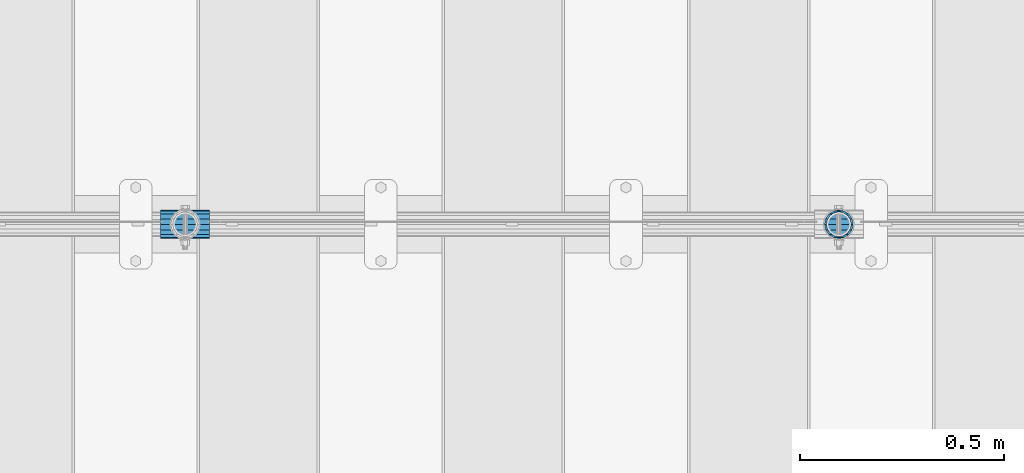
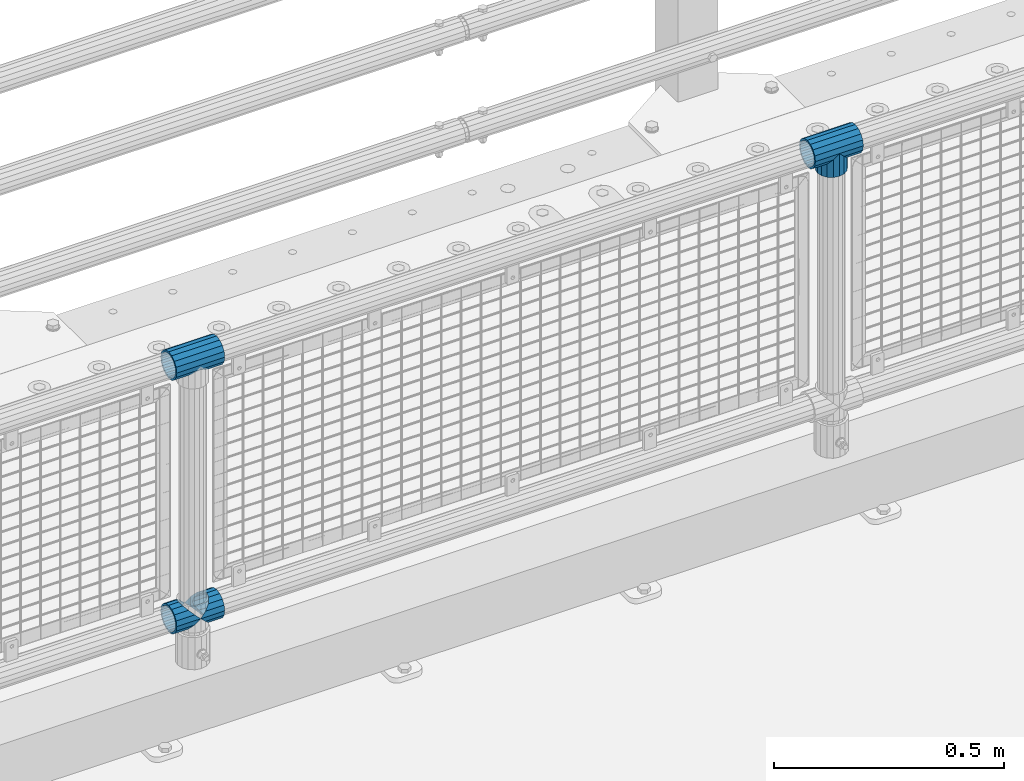
# One storey, part 150 of 257: 5 beams.
"""IFC2X3 building model written with IfcOpenShell, lengths in millimetres."""

from ifc_helpers import new_model, si_unit, frame, origin_with_axes, place, context, subcontext, project, spatial, faceted_brep, material, type_object, element, save


model = new_model("IFC2X3")

# Units and contexts
model_context = context("Model", 3, precision=1e-05, world=origin_with_axes())
body_context = subcontext(model_context, "Body", "Model", "MODEL_VIEW")
ifc_project = project(units=[si_unit("LENGTHUNIT", "METRE", prefix="MILLI"), si_unit("AREAUNIT", "SQUARE_METRE"), si_unit("VOLUMEUNIT", "CUBIC_METRE"), si_unit("MASSUNIT", "GRAM", prefix="KILO"), si_unit("TIMEUNIT", "SECOND"), si_unit("PLANEANGLEUNIT", "RADIAN"), si_unit("SOLIDANGLEUNIT", "STERADIAN"), si_unit("THERMODYNAMICTEMPERATUREUNIT", "DEGREE_CELSIUS"), si_unit("LUMINOUSINTENSITYUNIT", "LUMEN")], contexts=[model_context])

# Site, building, storey
site_placement = place(None, origin_with_axes())
site = spatial("IfcSite", under=ifc_project, at=site_placement, CompositionType="ELEMENT")
building_placement = place(site_placement, origin_with_axes())
building = spatial("IfcBuilding", under=site, at=building_placement, Name="Standard", CompositionType="ELEMENT")
storey_placement = place(building_placement, origin_with_axes())
storey = spatial("IfcBuildingStorey", under=building, at=storey_placement, Name="Undefined", CompositionType="ELEMENT", Elevation=0.0)

# Beams
ifc_material = material(Name="Misc_Undefined")
beam_type = type_object("IfcBeamType", PredefinedType="NOTDEFINED")
beam_1_placement = place(storey_placement, frame((47871.0, 10664.5, 969.849999999999), z_axis=(0.0, 1.0, 0.0), x_axis=(0.0, 0.0, -1.0)))
element("IfcBeam", 1, at=beam_1_placement, inside=storey, type_object=beam_type, material=ifc_material, context=body_context, shape_type="Brep", body=[
    faceted_brep([(0.0, 0.0, 35.1499999999996), (13.4513226476338, 13.4513226476329, 32.4743655677721), (13.4513226476338, -13.4513226476329, 32.4743655677721), (32.4743655677739, -32.4743655677717, -13.4513226476338), (32.4743655677739, -26.8123795176755, -13.4513226476338), (27.1226768591005, -21.4606908090117, -21.4606908090118), (24.8548033587067, -16.3810424080045, -24.8548033587067), (24.8548033587067, -24.8548033587072, -24.8548033587067), (13.4513226476338, -13.4513226476329, -32.4743655677721), (13.4513226476338, 13.4513226476329, -32.4743655677721), (0.0, 0.0, -35.1499999999996), (20.0882031229849, -11.6144421722805, -28.0397438117179), (16.6306603983685, 0.0, -30.3500000000004), (20.0882031229849, 11.6144421722805, -28.0397438117179), (24.8548033587067, 16.3810424080013, -24.8548033587067), (24.8548033587067, 24.8548033587072, -24.8548033587067), (32.4743655677739, 26.8123795176754, -13.4513226476338), (32.4743655677739, 32.4743655677717, -13.4513226476338), (27.1226768591005, 21.4606908090117, -21.4606908090118), (35.1500000000015, 30.35, 0.0), (35.1500000000015, 35.15, 0.0), (32.8397438117172, 28.0397438117175, -11.6144421722802), (32.8397438117172, 28.0397438117175, 11.6144421722802), (32.4743655677739, 26.8123795176755, 13.4513226476338), (32.4743655677739, 32.4743655677717, 13.4513226476338), (27.122676859115, 21.4606908090117, 21.4606908090118), (24.8548033587067, 16.3810424080013, 24.8548033587067), (24.8548033587067, 24.8548033587072, 24.8548033587067), (20.0882031229849, 11.6144421722805, 28.0397438117179), (16.6306603983758, 0.0, 30.3500000000004), (20.0882031229849, -11.6144421722805, 28.0397438117179), (24.8548033587067, -16.3810424080013, 24.8548033587067), (24.8548033587067, -24.8548033587072, 24.8548033587067), (27.122676859115, -21.4606908090117, 21.4606908090118), (32.4743655677739, -26.8123795176754, 13.4513226476338), (32.4743655677739, -32.4743655677717, 13.4513226476338), (32.8397438117172, -28.0397438117175, 11.6144421722802), (35.1500000000015, -30.35, 0.0), (35.1500000000015, -35.1499999999996, 0.0), (32.8397438117172, -28.0397438117175, -11.6144421722802), (60.1500000000015, -24.8548033587072, -24.8548033587067), (60.1500000000015, -32.4743655677717, -13.4513226476338), (60.1500000000015, -13.4513226476329, -32.4743655677721), (60.1500000000015, 0.0, -35.1499999999996), (60.1500000000015, 13.4513226476329, -32.4743655677721), (60.1500000000015, 24.8548033587072, -24.8548033587067), (60.1500000000015, 32.4743655677717, -13.4513226476338), (60.1500000000015, 35.15, 0.0), (60.1500000000015, 32.4743655677717, 13.4513226476338), (60.1500000000015, 24.8548033587072, 24.8548033587067), (60.1500000000015, 13.4513226476329, 32.4743655677721), (60.1500000000015, 0.0, 35.1499999999996), (60.1500000000015, -13.4513226476329, 32.4743655677721), (60.1500000000015, -24.8548033587072, 24.8548033587067), (60.1500000000015, -32.4743655677717, 13.4513226476338), (60.1500000000015, -35.15, 0.0), (60.1500000000015, -21.4606908090117, 21.4606908090118), (60.1500000000015, -11.6144421722805, 28.0397438117179), (60.1500000000015, 0.0, 30.3500000000004), (60.1500000000015, 11.6144421722805, 28.0397438117179), (60.1500000000015, 21.4606908090117, 21.4606908090118), (60.1500000000015, 28.0397438117175, 11.6144421722802), (60.1500000000015, 30.35, 0.0), (60.1500000000015, 28.0397438117175, -11.6144421722802), (60.1500000000015, 21.4606908090117, -21.4606908090118), (60.1500000000015, 11.6144421722805, -28.0397438117179), (60.1500000000015, 0.0, -30.3500000000004), (60.1500000000015, -11.6144421722805, -28.0397438117179), (60.1500000000015, -21.4606908090117, -21.4606908090118), (60.1500000000015, -28.0397438117175, -11.6144421722802), (60.1500000000015, -30.35, 0.0), (60.1500000000015, -28.0397438117175, 11.6144421722802)], [[[0, 1, 2]], [[3, 4, 5, 6, 7]], [[8, 9, 10]], [[7, 6, 11, 12, 13, 14, 15, 9, 8]], [[16, 17, 15, 14, 18]], [[19, 20, 17, 16, 21]], [[22, 23, 24, 20, 19]], [[25, 26, 27, 24, 23]], [[2, 1, 27, 26, 28, 29, 30, 31, 32]], [[32, 31, 33, 34, 35]], [[35, 34, 36, 37, 38]], [[38, 37, 39, 4, 3]], [[40, 41, 3, 7]], [[42, 40, 7, 8]], [[43, 42, 8, 10]], [[44, 43, 10, 9]], [[45, 44, 9, 15]], [[46, 45, 15, 17]], [[47, 46, 17, 20]], [[48, 47, 20, 24]], [[49, 48, 24, 27]], [[50, 49, 27, 1]], [[51, 50, 1, 0]], [[52, 51, 0, 2]], [[53, 52, 2, 32]], [[54, 53, 32, 35]], [[55, 54, 35, 38]], [[41, 55, 38, 3]], [[40, 42, 43, 44, 45, 46, 47, 48, 49, 50, 51, 52, 53, 54, 55, 41], [56, 57, 58, 59, 60, 61, 62, 63, 64, 65, 66, 67, 68, 69, 70, 71]], [[71, 70, 37, 36]], [[33, 56, 71, 36, 34]], [[30, 57, 56, 33, 31]], [[58, 57, 30, 29]], [[59, 58, 29, 28]], [[60, 59, 28, 26, 25]], [[61, 60, 25, 23, 22]], [[62, 61, 22, 19]], [[63, 62, 19, 21]], [[18, 64, 63, 21, 16]], [[13, 65, 64, 18, 14]], [[66, 65, 13, 12]], [[67, 66, 12, 11]], [[68, 67, 11, 6, 5]], [[69, 68, 5, 4, 39]], [[70, 69, 39, 37]]]),
])
beam_2_placement = place(storey_placement, frame((47810.85, 10664.5, 969.849999999999), z_axis=(0.0, 0.0, 1.0), x_axis=(1.0, 0.0, 0.0)))
element("IfcBeam", 2, at=beam_2_placement, inside=storey, type_object=beam_type, material=ifc_material, context=body_context, shape_type="Brep", body=[
    faceted_brep([(88.1897438117157, -11.6144421722802, -28.0397438117176), (88.1897438117157, -11.6144421722802, -32.8397438117175), (86.962379517674, -13.4513226476338, -32.4743655677718), (81.6106908090151, -21.4606908090118, -27.122676859108), (81.6106908090151, -21.4606908090118, -21.4606908090117), (76.5310424080017, -24.8548033587067, -24.8548033587072), (71.7644421722798, -28.0397438117179, -20.0882031229829), (71.7644421722798, -28.0397438117179, -11.6144421722805), (60.1500000000015, -30.3500000000004, -16.6306603983671), (60.1500000000015, -30.35, 0.0), (48.5355578277231, -28.0397438117179, -20.0882031229829), (48.5355578277231, -28.0397438117179, -11.6144421722805), (43.7689575920012, -24.8548033587067, -24.8548033587072), (38.6893091909878, -21.4606908090118, -27.122676859108), (38.6893091909878, -21.4606908090118, -21.4606908090117), (33.3376204823144, -13.4513226476338, -32.4743655677718), (32.1102561882872, -11.6144421722802, -32.8397438117175), (32.1102561882872, -11.6144421722802, -28.0397438117176), (29.8000000000029, 0.0, -35.15), (29.8000000000029, 0.0, -30.35), (32.1102561882872, 11.6144421722802, -32.8397438117178), (32.1102561882872, 11.6144421722802, -28.0397438117176), (33.3376204823289, 13.4513226476338, -32.4743655677718), (38.6893091909878, 21.4606908090118, -27.1226768591091), (38.6893091909878, 21.4606908090118, -21.4606908090117), (43.7689575920012, 24.8548033587067, -24.8548033587072), (48.5355578277231, 28.0397438117179, -20.0882031229829), (48.5355578277231, 28.0397438117179, -11.6144421722805), (60.1500000000015, 30.3500000000004, -16.6306603983671), (60.1500000000015, 30.35, 0.0), (71.7644421722798, 28.0397438117179, -20.0882031229829), (71.7644421722798, 28.0397438117179, -11.6144421722805), (76.5310424080017, 24.8548033587067, -24.8548033587072), (81.6106908090151, 21.4606908090118, -27.1226768591091), (81.6106908090151, 21.4606908090118, -21.4606908090117), (86.9623795176813, 13.4513226476338, -32.4743655677718), (88.1897438117157, 11.6144421722802, -32.8397438117178), (88.1897438117157, 11.6144421722802, -28.0397438117176), (90.5, 0.0, -35.15), (90.5, 0.0, -30.35), (0.0, -21.4606908090118, -21.4606908090136), (0.0, -28.0397438117179, -11.6144421722784), (0.0, -11.6144421722802, -28.0397438117143), (0.0, 0.0, -30.3499999999985), (0.0, 11.6144421722802, -28.0397438117143), (0.0, 21.4606908090118, -21.4606908090136), (0.0, 28.0397438117179, -11.6144421722784), (0.0, 30.3500000000004, 0.0), (0.0, 32.4743655677721, -13.4513226476338), (0.0, 35.1499999999996, 0.0), (120.300000000003, 35.1499999999996, 0.0), (120.300000000003, 32.4743655677721, -13.4513226476329), (0.0, 32.4743655677721, 13.4513226476338), (120.300000000003, 32.4743655677721, 13.4513226476329), (0.0, 24.8548033587067, 24.8548033587067), (120.300000000003, 24.8548033587067, 24.8548033587072), (0.0, 13.4513226476338, 32.4743655677739), (120.300000000003, 13.4513226476338, 32.4743655677718), (0.0, 0.0, 35.1499999999996), (120.300000000003, 0.0, 35.15), (0.0, -13.4513226476338, 32.4743655677739), (120.300000000003, -13.4513226476338, 32.4743655677718), (0.0, -24.8548033587067, 24.8548033587067), (120.300000000003, -24.8548033587067, 24.8548033587072), (0.0, -32.4743655677721, 13.4513226476338), (120.300000000003, -32.4743655677721, 13.4513226476329), (0.0, -35.1499999999996, 0.0), (120.300000000003, -35.1499999999996, 0.0), (0.0, -32.4743655677721, -13.4513226476338), (120.300000000003, -32.4743655677721, -13.4513226476329), (0.0, 24.8548033587067, -24.8548033587067), (0.0, 13.4513226476338, -32.4743655677739), (0.0, 0.0, -35.1499999999996), (0.0, -13.4513226476338, -32.4743655677739), (0.0, -24.8548033587067, -24.8548033587067), (0.0, 28.0397438117179, 11.6144421722784), (0.0, 21.4606908090118, 21.4606908090136), (0.0, 11.6144421722802, 28.0397438117143), (0.0, 0.0, 30.3499999999985), (0.0, -11.6144421722802, 28.0397438117143), (0.0, -21.4606908090118, 21.4606908090136), (0.0, -28.0397438117179, 11.6144421722784), (0.0, -30.3500000000004, 0.0), (120.300000000003, -30.3500000000004, 0.0), (120.300000000003, -28.0397438117179, -11.6144421722805), (120.300000000003, -21.4606908090118, -21.4606908090117), (120.300000000003, -11.6144421722802, -28.0397438117176), (120.300000000003, 0.0, -30.35), (120.300000000003, 21.4606908090118, -21.4606908090117), (120.300000000003, 28.0397438117179, -11.6144421722805), (120.300000000003, 11.6144421722802, -28.0397438117176), (120.300000000003, 30.3500000000004, 0.0), (120.300000000003, 28.0397438117179, 11.6144421722805), (120.300000000003, 21.4606908090118, 21.4606908090117), (120.300000000003, 11.6144421722802, 28.0397438117176), (120.300000000003, 0.0, 30.35), (120.300000000003, -11.6144421722802, 28.0397438117176), (120.300000000003, -21.4606908090118, 21.4606908090117), (120.300000000003, -28.0397438117179, 11.6144421722805), (120.300000000003, -24.8548033587067, -24.8548033587072), (120.300000000003, -13.4513226476338, -32.4743655677718), (120.300000000003, 0.0, -35.15), (120.300000000003, 13.4513226476338, -32.4743655677718), (120.300000000003, 24.8548033587067, -24.8548033587072)], [[[0, 1, 2, 3, 4]], [[4, 3, 5, 6, 7]], [[7, 6, 8, 9]], [[9, 8, 10, 11]], [[11, 10, 12, 13, 14]], [[14, 13, 15, 16, 17]], [[17, 16, 18, 19]], [[19, 18, 20, 21]], [[21, 20, 22, 23, 24]], [[24, 23, 25, 26, 27]], [[27, 26, 28, 29]], [[29, 28, 30, 31]], [[31, 30, 32, 33, 34]], [[34, 33, 35, 36, 37]], [[37, 36, 38, 39]], [[39, 38, 1, 0]], [[40, 41, 11, 14]], [[42, 40, 14, 17]], [[43, 42, 17, 19]], [[44, 43, 19, 21]], [[45, 44, 21, 24]], [[46, 45, 24, 27]], [[47, 46, 27, 29]], [[48, 49, 50, 51]], [[49, 52, 53, 50]], [[52, 54, 55, 53]], [[54, 56, 57, 55]], [[56, 58, 59, 57]], [[58, 60, 61, 59]], [[60, 62, 63, 61]], [[62, 64, 65, 63]], [[64, 66, 67, 65]], [[66, 68, 69, 67]], [[64, 62, 60, 58, 56, 54, 52, 49, 48, 70, 71, 72, 73, 74, 68, 66], [41, 40, 42, 43, 44, 45, 46, 47, 75, 76, 77, 78, 79, 80, 81, 82]], [[41, 82, 9, 11]], [[83, 84, 7, 9]], [[84, 85, 4, 7]], [[85, 86, 0, 4]], [[86, 87, 39, 0]], [[88, 89, 31, 34]], [[90, 88, 34, 37]], [[87, 90, 37, 39]], [[89, 91, 29, 31]], [[75, 47, 29, 91, 92]], [[76, 75, 92, 93]], [[77, 76, 93, 94]], [[78, 77, 94, 95]], [[79, 78, 95, 96]], [[80, 79, 96, 97]], [[81, 80, 97, 98]], [[9, 82, 81, 98, 83]], [[99, 100, 101, 102, 103, 51, 50, 53, 55, 57, 59, 61, 63, 65, 67, 69], [97, 96, 95, 94, 93, 92, 91, 89, 88, 90, 87, 86, 85, 84, 83, 98]], [[35, 102, 101, 38, 36]], [[32, 103, 102, 35, 33]], [[28, 26, 25, 70, 48, 51, 103, 32, 30]], [[22, 71, 70, 25, 23]], [[18, 72, 71, 22, 20]], [[73, 72, 18, 16, 15]], [[74, 73, 15, 13, 12]], [[99, 69, 68, 74, 12, 10, 8, 6, 5]], [[100, 99, 5, 3, 2]], [[101, 100, 2, 1, 38]]]),
])
beam_3_placement = place(storey_placement, frame((46210.85, 10664.5, 969.849999999999), z_axis=(0.0, 0.0, 1.0), x_axis=(1.0, 0.0, 0.0)))
element("IfcBeam", 3, at=beam_3_placement, inside=storey, type_object=beam_type, material=ifc_material, context=body_context, shape_type="Brep", body=[
    faceted_brep([(88.1897438117157, -11.6144421722802, -28.0397438117176), (88.1897438117157, -11.6144421722802, -32.8397438117175), (86.962379517674, -13.4513226476338, -32.4743655677718), (81.6106908090151, -21.4606908090118, -27.122676859108), (81.6106908090151, -21.4606908090118, -21.4606908090117), (76.5310424080017, -24.8548033587067, -24.8548033587072), (71.7644421722798, -28.0397438117179, -20.0882031229829), (71.7644421722798, -28.0397438117179, -11.6144421722805), (60.1500000000015, -30.3500000000004, -16.6306603983671), (60.1500000000015, -30.35, 0.0), (48.5355578277231, -28.0397438117179, -20.0882031229829), (48.5355578277231, -28.0397438117179, -11.6144421722805), (43.7689575920012, -24.8548033587067, -24.8548033587072), (38.6893091909878, -21.4606908090118, -27.122676859108), (38.6893091909878, -21.4606908090118, -21.4606908090117), (33.3376204823144, -13.4513226476338, -32.4743655677718), (32.1102561882872, -11.6144421722802, -32.8397438117175), (32.1102561882872, -11.6144421722802, -28.0397438117176), (29.8000000000029, 0.0, -35.15), (29.8000000000029, 0.0, -30.35), (32.1102561882872, 11.6144421722802, -32.8397438117178), (32.1102561882872, 11.6144421722802, -28.0397438117176), (33.3376204823289, 13.4513226476338, -32.4743655677718), (38.6893091909878, 21.4606908090118, -27.1226768591091), (38.6893091909878, 21.4606908090118, -21.4606908090117), (43.7689575920012, 24.8548033587067, -24.8548033587072), (48.5355578277231, 28.0397438117179, -20.0882031229829), (48.5355578277231, 28.0397438117179, -11.6144421722805), (60.1500000000015, 30.3500000000004, -16.6306603983671), (60.1500000000015, 30.35, 0.0), (71.7644421722798, 28.0397438117179, -20.0882031229829), (71.7644421722798, 28.0397438117179, -11.6144421722805), (76.5310424080017, 24.8548033587067, -24.8548033587072), (81.6106908090151, 21.4606908090118, -27.1226768591091), (81.6106908090151, 21.4606908090118, -21.4606908090117), (86.9623795176813, 13.4513226476338, -32.4743655677718), (88.1897438117157, 11.6144421722802, -32.8397438117178), (88.1897438117157, 11.6144421722802, -28.0397438117176), (90.5, 0.0, -35.15), (90.5, 0.0, -30.35), (0.0, -21.4606908090118, -21.4606908090136), (0.0, -28.0397438117179, -11.6144421722784), (0.0, -11.6144421722802, -28.0397438117143), (0.0, 0.0, -30.3499999999985), (0.0, 11.6144421722802, -28.0397438117143), (0.0, 21.4606908090118, -21.4606908090136), (0.0, 28.0397438117179, -11.6144421722784), (0.0, 30.3500000000004, 0.0), (0.0, 32.4743655677721, -13.4513226476338), (0.0, 35.1499999999996, 0.0), (120.300000000003, 35.1499999999996, 0.0), (120.300000000003, 32.4743655677721, -13.4513226476329), (0.0, 32.4743655677721, 13.4513226476338), (120.300000000003, 32.4743655677721, 13.4513226476329), (0.0, 24.8548033587067, 24.8548033587067), (120.300000000003, 24.8548033587067, 24.8548033587072), (0.0, 13.4513226476338, 32.4743655677739), (120.300000000003, 13.4513226476338, 32.4743655677718), (0.0, 0.0, 35.1499999999996), (120.300000000003, 0.0, 35.15), (0.0, -13.4513226476338, 32.4743655677739), (120.300000000003, -13.4513226476338, 32.4743655677718), (0.0, -24.8548033587067, 24.8548033587067), (120.300000000003, -24.8548033587067, 24.8548033587072), (0.0, -32.4743655677721, 13.4513226476338), (120.300000000003, -32.4743655677721, 13.4513226476329), (0.0, -35.1499999999996, 0.0), (120.300000000003, -35.1499999999996, 0.0), (0.0, -32.4743655677721, -13.4513226476338), (120.300000000003, -32.4743655677721, -13.4513226476329), (0.0, 24.8548033587067, -24.8548033587067), (0.0, 13.4513226476338, -32.4743655677739), (0.0, 0.0, -35.1499999999996), (0.0, -13.4513226476338, -32.4743655677739), (0.0, -24.8548033587067, -24.8548033587067), (0.0, 28.0397438117179, 11.6144421722784), (0.0, 21.4606908090118, 21.4606908090136), (0.0, 11.6144421722802, 28.0397438117143), (0.0, 0.0, 30.3499999999985), (0.0, -11.6144421722802, 28.0397438117143), (0.0, -21.4606908090118, 21.4606908090136), (0.0, -28.0397438117179, 11.6144421722784), (0.0, -30.3500000000004, 0.0), (120.300000000003, -30.3500000000004, 0.0), (120.300000000003, -28.0397438117179, -11.6144421722805), (120.300000000003, -21.4606908090118, -21.4606908090117), (120.300000000003, -11.6144421722802, -28.0397438117176), (120.300000000003, 0.0, -30.35), (120.300000000003, 21.4606908090118, -21.4606908090117), (120.300000000003, 28.0397438117179, -11.6144421722805), (120.300000000003, 11.6144421722802, -28.0397438117176), (120.300000000003, 30.3500000000004, 0.0), (120.300000000003, 28.0397438117179, 11.6144421722805), (120.300000000003, 21.4606908090118, 21.4606908090117), (120.300000000003, 11.6144421722802, 28.0397438117176), (120.300000000003, 0.0, 30.35), (120.300000000003, -11.6144421722802, 28.0397438117176), (120.300000000003, -21.4606908090118, 21.4606908090117), (120.300000000003, -28.0397438117179, 11.6144421722805), (120.300000000003, -24.8548033587067, -24.8548033587072), (120.300000000003, -13.4513226476338, -32.4743655677718), (120.300000000003, 0.0, -35.15), (120.300000000003, 13.4513226476338, -32.4743655677718), (120.300000000003, 24.8548033587067, -24.8548033587072)], [[[0, 1, 2, 3, 4]], [[4, 3, 5, 6, 7]], [[7, 6, 8, 9]], [[9, 8, 10, 11]], [[11, 10, 12, 13, 14]], [[14, 13, 15, 16, 17]], [[17, 16, 18, 19]], [[19, 18, 20, 21]], [[21, 20, 22, 23, 24]], [[24, 23, 25, 26, 27]], [[27, 26, 28, 29]], [[29, 28, 30, 31]], [[31, 30, 32, 33, 34]], [[34, 33, 35, 36, 37]], [[37, 36, 38, 39]], [[39, 38, 1, 0]], [[40, 41, 11, 14]], [[42, 40, 14, 17]], [[43, 42, 17, 19]], [[44, 43, 19, 21]], [[45, 44, 21, 24]], [[46, 45, 24, 27]], [[47, 46, 27, 29]], [[48, 49, 50, 51]], [[49, 52, 53, 50]], [[52, 54, 55, 53]], [[54, 56, 57, 55]], [[56, 58, 59, 57]], [[58, 60, 61, 59]], [[60, 62, 63, 61]], [[62, 64, 65, 63]], [[64, 66, 67, 65]], [[66, 68, 69, 67]], [[64, 62, 60, 58, 56, 54, 52, 49, 48, 70, 71, 72, 73, 74, 68, 66], [41, 40, 42, 43, 44, 45, 46, 47, 75, 76, 77, 78, 79, 80, 81, 82]], [[41, 82, 9, 11]], [[83, 84, 7, 9]], [[84, 85, 4, 7]], [[85, 86, 0, 4]], [[86, 87, 39, 0]], [[88, 89, 31, 34]], [[90, 88, 34, 37]], [[87, 90, 37, 39]], [[89, 91, 29, 31]], [[75, 47, 29, 91, 92]], [[76, 75, 92, 93]], [[77, 76, 93, 94]], [[78, 77, 94, 95]], [[79, 78, 95, 96]], [[80, 79, 96, 97]], [[81, 80, 97, 98]], [[9, 82, 81, 98, 83]], [[99, 100, 101, 102, 103, 51, 50, 53, 55, 57, 59, 61, 63, 65, 67, 69], [97, 96, 95, 94, 93, 92, 91, 89, 88, 90, 87, 86, 85, 84, 83, 98]], [[35, 102, 101, 38, 36]], [[32, 103, 102, 35, 33]], [[28, 26, 25, 70, 48, 51, 103, 32, 30]], [[22, 71, 70, 25, 23]], [[18, 72, 71, 22, 20]], [[73, 72, 18, 16, 15]], [[74, 73, 15, 13, 12]], [[99, 69, 68, 74, 12, 10, 8, 6, 5]], [[100, 99, 5, 3, 2]], [[101, 100, 2, 1, 38]]]),
])
beam_4_placement = place(storey_placement, frame((46210.85, 10664.5, 298.17), z_axis=(0.0, 1.0, 0.0), x_axis=(1.0, 0.0, 0.0)))
element("IfcBeam", 4, at=beam_4_placement, inside=storey, type_object=beam_type, material=ifc_material, context=body_context, shape_type="Brep", body=[
    faceted_brep([(60.1500000000015, 0.0, -35.1499999999996), (46.6986773523677, 13.4513226476329, -32.4743655677721), (46.6986773523677, -13.4513226476329, -32.4743655677721), (33.0273231408937, 21.4606908090117, 21.4606908090118), (27.6756344322275, 26.8123795176764, 13.4513226476338), (27.6756344322275, 32.4743655677717, 13.4513226476338), (35.2951966412948, 24.8548033587072, 24.8548033587067), (35.2951966412948, 16.3810424080013, 24.8548033587067), (27.3102561882843, 28.0397438117175, 11.6144421722802), (25.0, 30.35, 0.0), (25.0, 35.15, 0.0), (27.6756344322275, 26.8123795176754, -13.4513226476338), (27.6756344322275, 32.4743655677717, -13.4513226476338), (27.3102561882843, 28.0397438117175, -11.6144421722802), (35.2951966412948, 16.3810424080013, -24.8548033587067), (35.2951966412948, 24.8548033587072, -24.8548033587067), (33.0273231408864, 21.4606908090117, -21.4606908090118), (40.0617968770239, 11.6144421722805, -28.0397438117179), (43.5193396016475, 0.0, -30.3500000000004), (40.0617968770239, -11.6144421722805, -28.0397438117179), (35.2951966412948, -16.3810424080078, -24.8548033587067), (35.2951966412948, -24.8548033587072, -24.8548033587067), (33.0273231408864, -21.4606908090117, -21.4606908090118), (27.6756344322275, -26.8123795176764, -13.4513226476338), (27.6756344322275, -32.4743655677717, -13.4513226476338), (27.3102561882843, -28.0397438117175, -11.6144421722802), (25.0, -30.35, 0.0), (25.0, -35.15, 0.0), (27.3102561882843, -28.0397438117175, 11.6144421722802), (27.6756344322275, -26.8123795176754, 13.4513226476338), (27.6756344322275, -32.4743655677717, 13.4513226476338), (33.0273231408937, -21.4606908090117, 21.4606908090118), (35.2951966412948, -16.3810424080045, 24.8548033587067), (35.2951966412948, -24.8548033587072, 24.8548033587067), (60.1500000000015, 0.0, 35.1499999999996), (46.6986773523677, -13.4513226476329, 32.4743655677721), (46.6986773523677, 13.4513226476329, 32.4743655677721), (40.0617968770166, -11.6144421722805, 28.0397438117179), (43.519339601633, 0.0, 30.3500000000004), (40.0617968770166, 11.6144421722805, 28.0397438117179), (0.0, -32.4743655677721, -13.4513226476338), (0.0, -24.8548033587067, -24.8548033587067), (0.0, -13.4513226476338, -32.4743655677739), (0.0, 0.0, -35.1499999999996), (0.0, 13.4513226476338, -32.4743655677739), (0.0, 24.8548033587067, -24.8548033587067), (0.0, 32.4743655677721, -13.4513226476338), (0.0, 35.1499999999996, 0.0), (0.0, 32.4743655677721, 13.4513226476338), (0.0, 24.8548033587067, 24.8548033587067), (0.0, 13.4513226476338, 32.4743655677739), (0.0, 0.0, 35.1499999999996), (0.0, -32.4743655677721, 13.4513226476338), (0.0, -35.1499999999996, 0.0), (0.0, -24.8548033587067, 24.8548033587067), (0.0, -13.4513226476338, 32.4743655677739), (0.0, -28.0397438117179, -11.6144421722784), (0.0, -21.4606908090118, -21.4606908090136), (0.0, -11.6144421722802, -28.0397438117143), (0.0, 0.0, -30.3499999999985), (0.0, 11.6144421722802, -28.0397438117143), (0.0, 21.4606908090118, -21.4606908090136), (0.0, 28.0397438117179, -11.6144421722784), (0.0, 30.3500000000004, 0.0), (0.0, 28.0397438117179, 11.6144421722784), (0.0, 21.4606908090118, 21.4606908090136), (0.0, 11.6144421722802, 28.0397438117143), (0.0, 0.0, 30.3499999999985), (0.0, -11.6144421722802, 28.0397438117143), (0.0, -21.4606908090118, 21.4606908090136), (0.0, -28.0397438117179, 11.6144421722784), (0.0, -30.3500000000004, 0.0)], [[[0, 1, 2]], [[3, 4, 5, 6, 7]], [[8, 9, 10, 5, 4]], [[11, 12, 10, 9, 13]], [[14, 15, 12, 11, 16]], [[2, 1, 15, 14, 17, 18, 19, 20, 21]], [[21, 20, 22, 23, 24]], [[24, 23, 25, 26, 27]], [[27, 26, 28, 29, 30]], [[30, 29, 31, 32, 33]], [[34, 35, 36]], [[33, 32, 37, 38, 39, 7, 6, 36, 35]], [[40, 41, 21, 24]], [[41, 42, 2, 21]], [[42, 43, 0, 2]], [[43, 44, 1, 0]], [[44, 45, 15, 1]], [[45, 46, 12, 15]], [[46, 47, 10, 12]], [[47, 48, 5, 10]], [[48, 49, 6, 5]], [[49, 50, 36, 6]], [[50, 51, 34, 36]], [[52, 53, 27, 30]], [[54, 52, 30, 33]], [[55, 54, 33, 35]], [[51, 55, 35, 34]], [[53, 40, 24, 27]], [[52, 54, 55, 51, 50, 49, 48, 47, 46, 45, 44, 43, 42, 41, 40, 53], [56, 57, 58, 59, 60, 61, 62, 63, 64, 65, 66, 67, 68, 69, 70, 71]], [[68, 67, 38, 37]], [[31, 69, 68, 37, 32]], [[28, 70, 69, 31, 29]], [[71, 70, 28, 26]], [[56, 71, 26, 25]], [[57, 56, 25, 23, 22]], [[58, 57, 22, 20, 19]], [[59, 58, 19, 18]], [[60, 59, 18, 17]], [[16, 61, 60, 17, 14]], [[13, 62, 61, 16, 11]], [[63, 62, 13, 9]], [[64, 63, 9, 8]], [[65, 64, 8, 4, 3]], [[66, 65, 3, 7, 39]], [[67, 66, 39, 38]]]),
])
beam_5_placement = place(storey_placement, frame((46271.0, 10664.5, 298.17), z_axis=(0.0, 1.0, 0.0), x_axis=(1.0, 0.0, 0.0)))
element("IfcBeam", 5, at=beam_5_placement, inside=storey, type_object=beam_type, material=ifc_material, context=body_context, shape_type="Brep", body=[
    faceted_brep([(0.0, 0.0, 35.1499999999996), (13.4513226476338, 13.4513226476329, 32.4743655677721), (13.4513226476338, -13.4513226476329, 32.4743655677721), (32.4743655677739, -32.4743655677717, -13.4513226476338), (32.4743655677739, -26.8123795176755, -13.4513226476338), (27.1226768591005, -21.4606908090117, -21.4606908090118), (24.8548033587067, -16.3810424080045, -24.8548033587067), (24.8548033587067, -24.8548033587072, -24.8548033587067), (13.4513226476338, -13.4513226476329, -32.4743655677721), (13.4513226476338, 13.4513226476329, -32.4743655677721), (0.0, 0.0, -35.1499999999996), (20.0882031229849, -11.6144421722805, -28.0397438117179), (16.6306603983685, 0.0, -30.3500000000004), (20.0882031229849, 11.6144421722805, -28.0397438117179), (24.8548033587067, 16.3810424080013, -24.8548033587067), (24.8548033587067, 24.8548033587072, -24.8548033587067), (32.4743655677739, 26.8123795176754, -13.4513226476338), (32.4743655677739, 32.4743655677717, -13.4513226476338), (27.1226768591005, 21.4606908090117, -21.4606908090118), (35.1500000000015, 30.35, 0.0), (35.1500000000015, 35.15, 0.0), (32.8397438117172, 28.0397438117175, -11.6144421722802), (32.8397438117172, 28.0397438117175, 11.6144421722802), (32.4743655677739, 26.8123795176755, 13.4513226476338), (32.4743655677739, 32.4743655677717, 13.4513226476338), (27.122676859115, 21.4606908090117, 21.4606908090118), (24.8548033587067, 16.3810424080013, 24.8548033587067), (24.8548033587067, 24.8548033587072, 24.8548033587067), (20.0882031229849, 11.6144421722805, 28.0397438117179), (16.6306603983758, 0.0, 30.3500000000004), (20.0882031229849, -11.6144421722805, 28.0397438117179), (24.8548033587067, -16.3810424080013, 24.8548033587067), (24.8548033587067, -24.8548033587072, 24.8548033587067), (27.122676859115, -21.4606908090117, 21.4606908090118), (32.4743655677739, -26.8123795176754, 13.4513226476338), (32.4743655677739, -32.4743655677717, 13.4513226476338), (32.8397438117172, -28.0397438117175, 11.6144421722802), (35.1500000000015, -30.35, 0.0), (35.1500000000015, -35.1499999999996, 0.0), (32.8397438117172, -28.0397438117175, -11.6144421722802), (60.1500000000015, -24.8548033587072, -24.8548033587067), (60.1500000000015, -32.4743655677717, -13.4513226476338), (60.1500000000015, -13.4513226476329, -32.4743655677721), (60.1500000000015, 0.0, -35.1499999999996), (60.1500000000015, 13.4513226476329, -32.4743655677721), (60.1500000000015, 24.8548033587072, -24.8548033587067), (60.1500000000015, 32.4743655677717, -13.4513226476338), (60.1500000000015, 35.15, 0.0), (60.1500000000015, 32.4743655677717, 13.4513226476338), (60.1500000000015, 24.8548033587072, 24.8548033587067), (60.1500000000015, 13.4513226476329, 32.4743655677721), (60.1500000000015, 0.0, 35.1499999999996), (60.1500000000015, -13.4513226476329, 32.4743655677721), (60.1500000000015, -24.8548033587072, 24.8548033587067), (60.1500000000015, -32.4743655677717, 13.4513226476338), (60.1500000000015, -35.15, 0.0), (60.1500000000015, -21.4606908090117, 21.4606908090118), (60.1500000000015, -11.6144421722805, 28.0397438117179), (60.1500000000015, 0.0, 30.3500000000004), (60.1500000000015, 11.6144421722805, 28.0397438117179), (60.1500000000015, 21.4606908090117, 21.4606908090118), (60.1500000000015, 28.0397438117175, 11.6144421722802), (60.1500000000015, 30.35, 0.0), (60.1500000000015, 28.0397438117175, -11.6144421722802), (60.1500000000015, 21.4606908090117, -21.4606908090118), (60.1500000000015, 11.6144421722805, -28.0397438117179), (60.1500000000015, 0.0, -30.3500000000004), (60.1500000000015, -11.6144421722805, -28.0397438117179), (60.1500000000015, -21.4606908090117, -21.4606908090118), (60.1500000000015, -28.0397438117175, -11.6144421722802), (60.1500000000015, -30.35, 0.0), (60.1500000000015, -28.0397438117175, 11.6144421722802)], [[[0, 1, 2]], [[3, 4, 5, 6, 7]], [[8, 9, 10]], [[7, 6, 11, 12, 13, 14, 15, 9, 8]], [[16, 17, 15, 14, 18]], [[19, 20, 17, 16, 21]], [[22, 23, 24, 20, 19]], [[25, 26, 27, 24, 23]], [[2, 1, 27, 26, 28, 29, 30, 31, 32]], [[32, 31, 33, 34, 35]], [[35, 34, 36, 37, 38]], [[38, 37, 39, 4, 3]], [[40, 41, 3, 7]], [[42, 40, 7, 8]], [[43, 42, 8, 10]], [[44, 43, 10, 9]], [[45, 44, 9, 15]], [[46, 45, 15, 17]], [[47, 46, 17, 20]], [[48, 47, 20, 24]], [[49, 48, 24, 27]], [[50, 49, 27, 1]], [[51, 50, 1, 0]], [[52, 51, 0, 2]], [[53, 52, 2, 32]], [[54, 53, 32, 35]], [[55, 54, 35, 38]], [[41, 55, 38, 3]], [[40, 42, 43, 44, 45, 46, 47, 48, 49, 50, 51, 52, 53, 54, 55, 41], [56, 57, 58, 59, 60, 61, 62, 63, 64, 65, 66, 67, 68, 69, 70, 71]], [[71, 70, 37, 36]], [[33, 56, 71, 36, 34]], [[30, 57, 56, 33, 31]], [[58, 57, 30, 29]], [[59, 58, 29, 28]], [[60, 59, 28, 26, 25]], [[61, 60, 25, 23, 22]], [[62, 61, 22, 19]], [[63, 62, 19, 21]], [[18, 64, 63, 21, 16]], [[13, 65, 64, 18, 14]], [[66, 65, 13, 12]], [[67, 66, 12, 11]], [[68, 67, 11, 6, 5]], [[69, 68, 5, 4, 39]], [[70, 69, 39, 37]]]),
])

save(model, "model.ifc")
